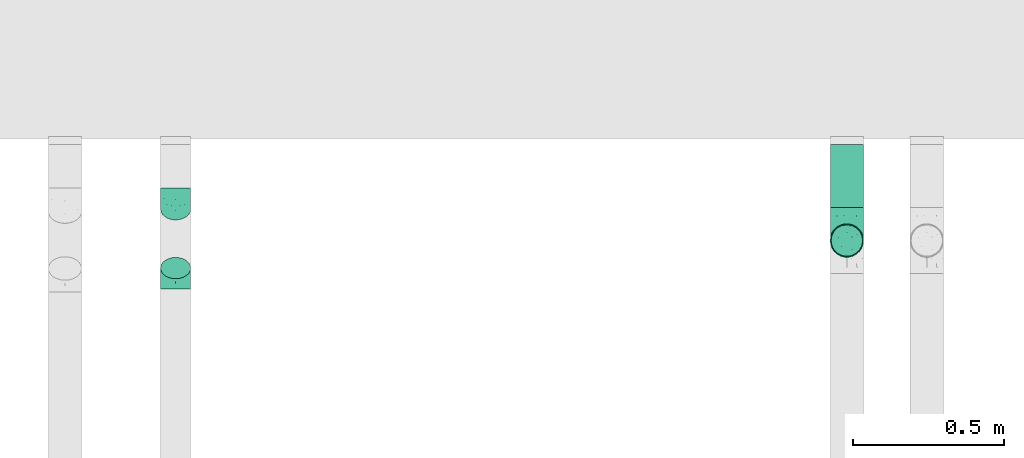
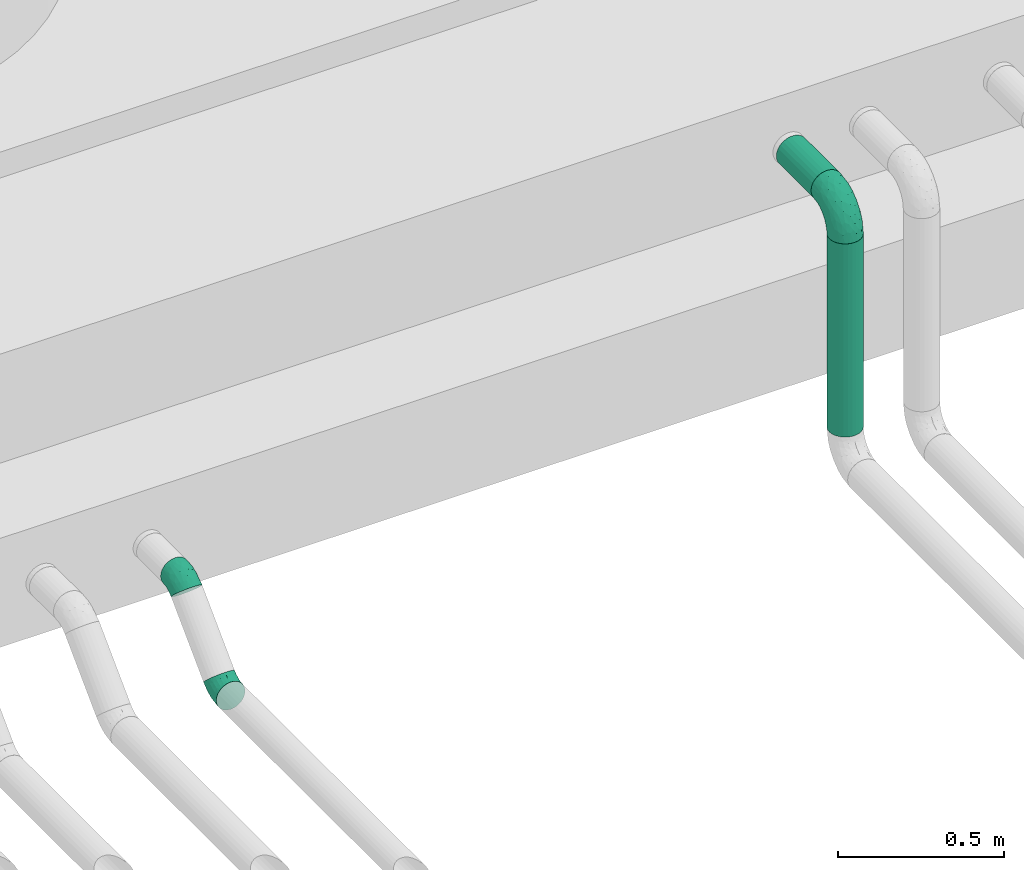
# One storey, part 55 of 91: 3 flow fittings, 2 flow segments.
"""IFC2X3 building model written with IfcOpenShell, lengths in millimetres."""

from ifc_helpers import new_model, entity, si_unit, converted_unit, derived_unit, direction, frame, origin_with_axes, origin_2d_with_axis, place, context, subcontext, project, spatial, hollow_circle, extrude, open_shell, surface_model, source, transform, mapped, material, layer, layer_set, layer_usage, type_object, element, save


model = new_model("IFC2X3")

# Units and contexts
model_context = context("Model", 3, precision=1e-05, world=origin_with_axes(), true_north=direction((0.0, 1.0)))
body_context = subcontext(model_context, "Body", "Model", "MODEL_VIEW")
ifc_project = project(units=[si_unit("AREAUNIT", "SQUARE_METRE"), si_unit("VOLUMEUNIT", "CUBIC_METRE", prefix="DECI"), si_unit("TIMEUNIT", "SECOND"), si_unit("THERMODYNAMICTEMPERATUREUNIT", "DEGREE_CELSIUS"), si_unit("PRESSUREUNIT", "PASCAL"), si_unit("MASSUNIT", "GRAM", prefix="KILO"), si_unit("LENGTHUNIT", "METRE", prefix="MILLI"), si_unit("POWERUNIT", "WATT"), si_unit("ELECTRICCURRENTUNIT", "AMPERE"), si_unit("ELECTRICVOLTAGEUNIT", "VOLT"), derived_unit("VOLUMETRICFLOWRATEUNIT", [(si_unit("VOLUMEUNIT", "CUBIC_METRE", prefix="DECI"), 1), (si_unit("TIMEUNIT", "SECOND"), -1)]), derived_unit("LINEARVELOCITYUNIT", [(si_unit("LENGTHUNIT", "METRE"), 1), (si_unit("TIMEUNIT", "SECOND"), -1)]), derived_unit("MASSDENSITYUNIT", [(si_unit("MASSUNIT", "GRAM", prefix="KILO"), 1), (si_unit("VOLUMEUNIT", "CUBIC_METRE"), -1)]), converted_unit("PLANEANGLEUNIT", "DEGREE", entity("IfcRatioMeasure", 0.01745), si_unit("PLANEANGLEUNIT", "RADIAN"), dimensions=[0, 0, 0, 0, 0, 0, 0])], contexts=[model_context])

# Site, building, storey
site_placement = place(None, origin_with_axes())
site = spatial("IfcSite", under=ifc_project, at=site_placement, CompositionType="ELEMENT")
building_placement = place(site_placement, origin_with_axes())
building = spatial("IfcBuilding", under=site, at=building_placement, Name="mc-building", CompositionType="ELEMENT")
storey_placement = place(building_placement, frame((0.0, 0.0, 8700.0), z_axis=(0.0, 0.0, 1.0), x_axis=(1.0, 0.0, 0.0)))
storey = spatial("IfcBuildingStorey", under=building, at=storey_placement, CompositionType="ELEMENT", Elevation=8700.0)

# Flow segments
ifc_material = material(Name="FZ1")
ifc_layer = layer(ifc_material, 0.0)
ifc_layer_set = layer_set([ifc_layer], Name="FZ1")
ifc_layer_usage = layer_usage(ifc_layer_set, "AXIS1", "POSITIVE", 0.0)
duct_segment_type = type_object("IfcDuctSegmentType", PredefinedType="RIGIDSEGMENT")
shared_shape_1 = source(origin_with_axes(), body_context, "Body", "SweptSolid", [
    extrude(hollow_circle(Radius=55.0, WallThickness=2.0, at=origin_2d_with_axis()), frame((0.0, 0.0, 0.0), z_axis=(1.0, 0.0, 0.0), x_axis=(0.0, 1.0, 0.0)), (0.0, 0.0, 1.0), 709.0),
])
flow_segment_1_placement = place(storey_placement, frame((29788.00747, 2612.35324, 1234.0), z_axis=(0.0, 1.0, 0.0), x_axis=(0.0, 0.0, -1.0)))
element("IfcFlowSegment", 1, at=flow_segment_1_placement, inside=storey, type_object=duct_segment_type, material=ifc_layer_usage, context=body_context, shape_type="MappedRepresentation", body=[
    mapped(shared_shape_1, transform((0.0, 0.0, 0.0), scale=1.0)),
])
shared_shape_2 = source(origin_with_axes(), body_context, "Body", "SweptSolid", [
    extrude(hollow_circle(Radius=55.0, WallThickness=2.0, at=origin_2d_with_axis()), frame((0.0, 0.0, 0.0), z_axis=(1.0, 0.0, 0.0), x_axis=(0.0, 1.0, 0.0)), (0.0, 0.0, 1.0), 208.9),
])
flow_segment_2_placement = place(storey_placement, frame((29788.00747, 2931.20513, 1344.0), z_axis=(0.0, 0.0, 1.0), x_axis=(0.0, -1.0, 0.0)))
element("IfcFlowSegment", 2, at=flow_segment_2_placement, inside=storey, type_object=duct_segment_type, material=ifc_layer_usage, context=body_context, shape_type="MappedRepresentation", body=[
    mapped(shared_shape_2, transform((0.0, 0.0, 0.0), scale=1.0)),
])

# Flow fittings
duct_fitting_type = type_object("IfcDuctFittingType", Name="BU", PredefinedType="BEND")
shared_shape_3 = source(origin_with_axes(), body_context, "Body", "SurfaceModel", [
    surface_model("IfcShellBasedSurfaceModel", [(-110.0, 0.0, -55.0), (-110.0, -14.23505, -53.12592), (-110.0, 14.23505, -53.12592), (-110.0, 53.12592, 14.23505), (-110.0, 27.5, -47.63139), (-110.0, 38.89087, -38.89087), (-110.0, -55.0, 0.0), (-110.0, -53.12592, 14.23505), (-110.0, -38.89087, -38.89087), (-110.0, -27.5, -47.63139), (-110.0, -53.12592, -14.23505), (-110.0, -47.63139, -27.5), (-110.0, -14.23505, 53.12592), (-110.0, 14.23505, 53.12592), (-110.0, 27.5, 47.63139), (-110.0, -47.63139, 27.5), (-110.0, -38.89087, 38.89087), (-110.0, -27.5, 47.63139), (-110.0, 0.0, 55.0), (-110.0, 55.0, 0.0), (-110.0, 53.12592, -14.23505), (-110.0, 47.63139, -27.5), (-110.0, 47.63139, 27.5), (-110.0, 38.89087, 38.89087), (-14.23505, 110.0, -53.12592), (-55.0, 110.0, 0.0), (0.0, 110.0, -55.0), (-27.5, 110.0, -47.63139), (-38.89087, 110.0, -38.89087), (-47.63139, 110.0, -27.5), (38.89087, 110.0, -38.89087), (53.12592, 110.0, 14.23505), (27.5, 110.0, -47.63139), (14.23505, 110.0, -53.12592), (47.63139, 110.0, -27.5), (53.12592, 110.0, -14.23505), (55.0, 110.0, 0.0), (-53.12592, 110.0, -14.23505), (-53.12592, 110.0, 14.23505), (-47.63139, 110.0, 27.5), (-38.89087, 110.0, 38.89087), (-27.5, 110.0, 47.63139), (0.0, 110.0, 55.0), (-14.23505, 110.0, 53.12592), (38.89087, 110.0, 38.89087), (47.63139, 110.0, 27.5), (27.5, 110.0, 47.63139), (14.23505, 110.0, 53.12592), (-64.21732, 48.68956, 43.63444), (-76.6405, 38.18013, 45.55988), (-60.44912, 32.56953, 51.94617), (-76.00813, 5.38378, 55.0), (-90.15553, 11.94394, 54.09138), (-78.5998, 26.77405, 50.81338), (-70.18771, 18.55163, 54.03432), (-75.55424, 54.2118, 32.41257), (-93.27622, 45.77614, 33.48188), (-96.12334, 22.13664, 50.81337), (-21.00813, 45.34362, 55.0), (-18.36258, 70.48427, 54.04484), (-32.04182, 59.64019, 52.24446), (-63.88653, 74.77858, 17.99134), (-74.66383, 63.08407, 19.92123), (-63.60674, 66.07878, 29.97482), (-99.597, 52.72185, 18.52927), (-93.11138, 56.59448, 10.50359), (-98.21577, 57.34403, 0.0), (-53.42855, 92.60092, 21.04759), (-88.54852, 54.8376, 21.04759), (-11.86161, 90.23965, 54.10313), (-5.38378, 76.00813, 55.0), (-57.34403, 98.21577, 0.0), (-56.64619, 93.12774, 10.22088), (-45.34362, 21.00813, 55.0), (-44.60838, 44.60838, 52.13415), (-92.68484, 35.46673, 43.63443), (-22.25266, 95.40765, 50.81337), (-35.97783, 90.61597, 43.63443), (-43.70931, 69.58671, 44.47149), (-27.23711, 77.39884, 50.81337), (-57.2828, 79.3123, 24.9774), (-58.67786, 84.31125, 16.04456), (-82.93277, 60.36161, 12.91784), (-49.88337, 54.51816, 47.224), (-74.57753, 66.83759, 9.55742), (-45.35812, 94.97281, 33.48188), (-59.18663, 88.95241, 0.0), (-51.517, 78.6292, 33.48188), (-65.14788, 80.03077, 0.0), (-56.45322, 62.06476, 39.63545), (-88.95241, 59.18663, 0.0), (-71.10913, 71.10913, 0.0), (-80.03077, 65.14788, 0.0), (-94.9309, 45.36788, -33.48188), (-93.11358, 56.60141, -10.46614), (-99.64997, 52.79499, -18.30015), (-90.20425, 36.08686, -43.63443), (-79.99933, 46.56772, -37.92748), (-76.00813, 5.38378, -55.0), (-72.75364, 19.68651, -53.60527), (-45.34362, 21.00813, -55.0), (-21.91957, 65.12078, -53.85897), (-5.38378, 76.00813, -55.0), (-21.00813, 45.34362, -55.0), (-35.41876, 92.89265, -43.63443), (-91.10309, 11.02766, -54.21832), (-45.77614, 93.27622, -33.48188), (-90.50474, 23.21022, -50.81337), (-70.92854, 33.31794, -49.51754), (-78.52933, 63.35627, -11.73997), (-24.91508, 84.05606, -50.81337), (-88.78941, 54.74452, -21.04759), (-69.59921, 57.34866, -33.48187), (-73.36422, 62.46673, -22.94182), (-63.49062, 67.59111, -28.46929), (-56.59448, 93.11138, -10.50359), (-54.8376, 88.54852, -21.04759), (-54.10679, 75.85581, -32.31867), (-57.75956, 31.09612, -52.80882), (-52.72185, 99.597, -18.52927), (-12.62913, 89.46304, -53.99097), (-34.46825, 66.46123, -50.04329), (-43.9837, 43.9837, -52.42279), (-65.78527, 72.58348, -17.68796), (-70.34468, 43.65295, -44.21951), (-57.47001, 51.99467, -44.91465), (-60.72547, 82.29174, -12.88567), (-42.34915, 74.24548, -43.63444), (-57.25194, 63.5016, -38.08211), (-80.95344, 53.56991, -29.32027), (-52.32891, 4.55257, -54.0482), (32.52942, 47.13398, -30.48571), (14.88266, 20.92917, -33.7947), (14.95561, 36.05775, -42.26543), (30.24048, 70.09027, -41.7461), (19.3559, 65.35825, -48.00507), (-70.35075, -46.44478, -19.5952), (-47.13398, -32.52942, -30.48571), (-28.49299, -30.5778, -16.4009), (-4.55257, 52.32891, -54.0482), (-22.4954, 22.4954, -53.25347), (-75.47368, -11.22546, -52.60718), (-81.32209, -51.5606, -9.98467), (-80.81763, -41.84862, -32.14655), (-70.09027, -30.24048, -41.7461), (-36.05774, -14.95561, -42.26543), (-9.15831, -10.852, -27.8997), (-65.35825, -19.3559, -48.00507), (11.22546, 75.47368, -52.60718), (3.94376, 43.9333, -50.53315), (-13.39742, 13.39743, -48.13058), (-43.9333, -3.94376, -50.53315), (49.37776, 67.29486, 0.0), (41.8609, 47.82256, -9.92641), (50.20582, 74.51695, -9.9731), (18.93131, 11.7156, -17.56239), (-27.5, -32.89419, 0.0), (-1.23348, -12.25375, -12.18106), (41.84862, 80.81763, -32.14655), (35.70604, 41.31408, -20.38235), (46.44478, 70.35075, -19.5952), (32.89419, 27.5, 0.0), (6.67262, -6.67262, 0.0), (-67.29486, -49.37776, 0.0), (-50.36265, -42.95545, -9.51562), (-5.47251, 5.47251, -39.92906), (-70.35075, -46.44478, 19.5952), (-74.51695, -50.20582, 9.9731), (-41.31407, -35.70604, 20.38235), (-47.13398, -32.52942, 30.48571), (-80.81763, -41.84862, 32.14655), (-4.55257, 52.32891, 54.0482), (11.22546, 75.47368, 52.60718), (-43.9333, -3.94376, 50.53315), (-65.35825, -19.3559, 48.00507), (-36.05774, -14.95561, 42.26543), (-70.09027, -30.24048, 41.7461), (-11.7156, -18.93131, 17.56239), (30.5778, 28.49299, 16.4009), (12.25375, 1.23348, 12.18106), (51.5606, 81.32209, 9.98467), (42.95545, 50.36265, 9.51562), (-75.47368, -11.22546, 52.60718), (-52.32891, 4.55257, 54.0482), (3.94376, 43.9333, 50.53315), (-22.4954, 22.4954, 53.25347), (-13.39742, 13.39743, 48.13058), (10.852, 9.15831, 27.8997), (-20.92916, -14.88266, 33.79469), (-47.82256, -41.8609, 9.92641), (32.52942, 47.13398, 30.48571), (46.44478, 70.35075, 19.5952), (41.84862, 80.81763, 32.14655), (30.24048, 70.09027, 41.7461), (19.3559, 65.35825, 48.00507), (14.95561, 36.05775, 42.26543), (-5.47251, 5.47251, 39.92906)], [open_shell([[[0, 1, 2]], [[2, 3, 4]], [[4, 3, 5]], [[2, 6, 7]], [[8, 6, 9]], [[1, 9, 6]], [[10, 6, 11]], [[8, 11, 6]], [[6, 2, 1]], [[12, 13, 14]], [[15, 2, 7]], [[16, 17, 2]], [[2, 17, 12]], [[12, 18, 13]], [[19, 20, 3]], [[5, 3, 21]], [[20, 21, 3]], [[22, 3, 2]], [[23, 22, 2]], [[12, 14, 2]], [[2, 14, 23]], [[15, 16, 2]], [[24, 25, 26]], [[27, 25, 24]], [[25, 28, 29]], [[28, 25, 27]], [[30, 26, 31]], [[26, 30, 32]], [[32, 33, 26]], [[34, 31, 35]], [[31, 34, 30]], [[35, 31, 36]], [[29, 37, 25]], [[38, 39, 26]], [[39, 40, 26]], [[41, 42, 40]], [[42, 26, 40]], [[42, 41, 43]], [[26, 44, 45]], [[31, 26, 45]], [[26, 46, 44]], [[47, 46, 26]], [[42, 47, 26]], [[25, 38, 26]], [[48, 49, 50]], [[18, 51, 52]], [[53, 54, 50]], [[55, 56, 49]], [[56, 22, 23]], [[13, 57, 14]], [[58, 59, 60]], [[61, 62, 63]], [[3, 64, 65]], [[53, 52, 54]], [[3, 65, 66]], [[67, 39, 38]], [[56, 68, 64]], [[65, 64, 68]], [[69, 59, 70]], [[38, 71, 72]], [[73, 58, 74]], [[75, 49, 56]], [[76, 69, 43]], [[53, 57, 52]], [[77, 78, 79]], [[41, 76, 43]], [[43, 69, 42]], [[55, 68, 56]], [[23, 14, 75]], [[76, 77, 79]], [[80, 67, 81]], [[62, 82, 68]], [[60, 78, 83]], [[62, 84, 82]], [[85, 77, 40]], [[81, 67, 72]], [[86, 72, 71]], [[87, 85, 67]], [[61, 81, 88]], [[77, 41, 40]], [[78, 77, 87]], [[23, 75, 56]], [[83, 89, 48]], [[85, 40, 39]], [[62, 68, 55]], [[89, 87, 63]], [[83, 48, 50]], [[57, 75, 14]], [[49, 75, 53]], [[67, 85, 39]], [[87, 77, 85]], [[63, 62, 55]], [[89, 55, 48]], [[80, 63, 87]], [[66, 65, 90]], [[66, 19, 3]], [[84, 91, 92]], [[92, 90, 82]], [[65, 82, 90]], [[61, 84, 62]], [[92, 82, 84]], [[68, 82, 65]], [[3, 22, 64]], [[56, 64, 22]], [[38, 25, 71]], [[81, 72, 86]], [[38, 72, 67]], [[91, 61, 88]], [[80, 81, 61]], [[63, 80, 61]], [[67, 80, 87]], [[77, 76, 41]], [[79, 59, 69]], [[79, 69, 76]], [[42, 69, 70]], [[60, 59, 79]], [[58, 70, 59]], [[78, 60, 79]], [[58, 60, 74]], [[52, 57, 13]], [[75, 57, 53]], [[18, 52, 13]], [[52, 51, 54]], [[51, 73, 54]], [[50, 73, 74]], [[73, 50, 54]], [[50, 74, 83]], [[60, 83, 74]], [[89, 83, 78]], [[87, 89, 78]], [[55, 89, 63]], [[50, 49, 53]], [[55, 49, 48]], [[81, 86, 88]], [[91, 84, 61]], [[5, 21, 93]], [[90, 94, 66]], [[20, 94, 95]], [[96, 93, 97]], [[98, 99, 100]], [[96, 4, 5]], [[101, 102, 103]], [[28, 27, 104]], [[2, 105, 0]], [[104, 106, 28]], [[99, 105, 107]], [[108, 107, 96]], [[90, 109, 94]], [[107, 2, 4]], [[20, 66, 94]], [[27, 24, 110]], [[109, 111, 94]], [[112, 113, 114]], [[37, 115, 71]], [[116, 106, 117]], [[99, 118, 100]], [[116, 115, 119]], [[37, 119, 115]], [[24, 120, 110]], [[121, 110, 101]], [[119, 106, 116]], [[101, 110, 120]], [[122, 103, 100]], [[117, 123, 116]], [[124, 125, 108]], [[115, 116, 126]], [[106, 29, 28]], [[26, 102, 120]], [[127, 104, 110]], [[97, 124, 96]], [[125, 122, 118]], [[128, 127, 125]], [[96, 5, 93]], [[115, 126, 86]], [[117, 106, 127]], [[111, 113, 129]], [[95, 93, 21]], [[97, 129, 112]], [[110, 104, 27]], [[106, 104, 127]], [[96, 107, 4]], [[99, 107, 108]], [[99, 108, 118]], [[105, 99, 98]], [[112, 114, 128]], [[121, 125, 127]], [[20, 19, 66]], [[109, 90, 92]], [[94, 111, 95]], [[91, 123, 109]], [[129, 113, 112]], [[93, 95, 111]], [[21, 20, 95]], [[71, 115, 86]], [[71, 25, 37]], [[123, 91, 88]], [[126, 116, 123]], [[123, 88, 126]], [[86, 126, 88]], [[37, 29, 119]], [[106, 119, 29]], [[129, 93, 111]], [[124, 112, 125]], [[0, 105, 98]], [[107, 105, 2]], [[125, 118, 108]], [[100, 118, 122]], [[93, 129, 97]], [[113, 111, 109]], [[109, 123, 113]], [[114, 123, 117]], [[123, 114, 113]], [[128, 114, 117]], [[127, 128, 117]], [[112, 128, 125]], [[103, 122, 101]], [[110, 121, 127]], [[101, 122, 121]], [[125, 121, 122]], [[26, 120, 24]], [[101, 120, 102]], [[96, 124, 108]], [[92, 91, 109]], [[112, 124, 97]], [[100, 130, 98]], [[131, 132, 133]], [[32, 134, 135]], [[136, 137, 138]], [[139, 140, 103]], [[98, 141, 0]], [[142, 10, 136]], [[143, 144, 137]], [[6, 10, 142]], [[137, 145, 146]], [[144, 147, 145]], [[143, 136, 11]], [[11, 136, 10]], [[8, 143, 11]], [[148, 149, 139]], [[8, 9, 144]], [[9, 1, 147]], [[130, 141, 98]], [[103, 140, 100]], [[148, 135, 149]], [[150, 151, 140]], [[152, 153, 154]], [[130, 140, 151]], [[148, 26, 33]], [[147, 1, 141]], [[155, 146, 132]], [[156, 138, 157]], [[134, 30, 158]], [[150, 140, 149]], [[158, 30, 34]], [[30, 134, 32]], [[153, 159, 160]], [[131, 160, 159]], [[144, 145, 137]], [[36, 152, 154]], [[146, 138, 137]], [[155, 161, 162]], [[158, 160, 131]], [[133, 149, 135]], [[156, 163, 164]], [[163, 142, 164]], [[139, 103, 102]], [[153, 152, 161]], [[34, 35, 160]], [[162, 157, 155]], [[132, 165, 133]], [[157, 146, 155]], [[140, 130, 100]], [[141, 130, 151]], [[141, 151, 147]], [[141, 1, 0]], [[102, 26, 148]], [[140, 139, 149]], [[102, 148, 139]], [[135, 33, 32]], [[151, 150, 145]], [[9, 147, 144]], [[151, 145, 147]], [[145, 165, 146]], [[135, 148, 33]], [[133, 135, 134]], [[131, 133, 134]], [[133, 165, 150]], [[133, 150, 149]], [[145, 150, 165]], [[132, 131, 159]], [[146, 165, 132]], [[160, 158, 34]], [[134, 158, 131]], [[144, 143, 8]], [[136, 143, 137]], [[155, 153, 161]], [[154, 153, 160]], [[153, 155, 159]], [[132, 159, 155]], [[160, 35, 154]], [[36, 154, 35]], [[164, 136, 138]], [[6, 142, 163]], [[136, 164, 142]], [[156, 164, 138]], [[156, 157, 162]], [[146, 157, 138]], [[15, 7, 166]], [[6, 163, 167]], [[168, 169, 166]], [[166, 169, 170]], [[171, 172, 70]], [[173, 174, 175]], [[17, 176, 174]], [[177, 156, 162]], [[176, 16, 170]], [[170, 16, 15]], [[161, 178, 179]], [[152, 180, 181]], [[182, 173, 183]], [[18, 12, 182]], [[184, 185, 186]], [[183, 185, 73]], [[183, 73, 51]], [[177, 187, 188]], [[189, 168, 166]], [[187, 178, 190]], [[16, 176, 17]], [[161, 152, 181]], [[45, 191, 31]], [[45, 44, 192]], [[192, 191, 45]], [[180, 36, 31]], [[193, 194, 195]], [[46, 47, 194]], [[193, 195, 190]], [[193, 44, 46]], [[172, 42, 70]], [[185, 58, 73]], [[189, 163, 156]], [[163, 189, 167]], [[70, 58, 171]], [[184, 171, 185]], [[169, 188, 175]], [[180, 31, 191]], [[192, 193, 190]], [[191, 190, 178]], [[182, 174, 173]], [[194, 47, 172]], [[190, 195, 187]], [[186, 185, 173]], [[162, 179, 177]], [[188, 196, 175]], [[179, 187, 177]], [[185, 171, 58]], [[172, 171, 184]], [[172, 184, 194]], [[172, 47, 42]], [[51, 18, 182]], [[185, 183, 173]], [[51, 182, 183]], [[174, 12, 17]], [[184, 186, 195]], [[46, 194, 193]], [[184, 195, 194]], [[195, 196, 187]], [[174, 182, 12]], [[175, 174, 176]], [[169, 175, 176]], [[175, 196, 186]], [[175, 186, 173]], [[195, 186, 196]], [[188, 169, 168]], [[187, 196, 188]], [[166, 170, 15]], [[176, 170, 169]], [[193, 192, 44]], [[191, 192, 190]], [[177, 189, 156]], [[167, 189, 166]], [[189, 177, 168]], [[188, 168, 177]], [[166, 7, 167]], [[6, 167, 7]], [[181, 191, 178]], [[36, 180, 152]], [[191, 181, 180]], [[161, 181, 178]], [[161, 179, 162]], [[187, 179, 178]]])]),
])
flow_fitting_placement = place(storey_placement, frame((29788.00747, 2612.35324, 1344.0), z_axis=(-1.0, 0.0, 0.0), x_axis=(0.0, 0.0, 1.0)))
element("IfcFlowFitting", 3, at=flow_fitting_placement, inside=storey, type_object=duct_fitting_type, Name="BU", context=body_context, shape_type="MappedRepresentation", body=[
    mapped(shared_shape_3, transform((0.0, 0.0, 0.0), scale=1.0)),
])
shared_shape_4 = source(origin_with_axes(), body_context, "Body", "SurfaceModel", [
    surface_model("IfcShellBasedSurfaceModel", [(-41.0, 0.0, -50.0), (-41.0, -12.94095, -48.29629), (-41.0, 12.94095, -48.29629), (-41.0, 48.29629, 12.94095), (-41.0, 25.0, -43.30127), (-41.0, 43.30127, -25.0), (-41.0, 35.35534, -35.35534), (-41.0, -50.0, 0.0), (-41.0, -48.29629, 12.94095), (-41.0, -35.35534, -35.35534), (-41.0, -25.0, -43.30127), (-41.0, -48.29629, -12.94095), (-41.0, -43.30127, -25.0), (-41.0, 48.29629, -12.94095), (-41.0, 43.30127, 25.0), (-41.0, 35.35534, 35.35534), (-41.0, -12.94095, 48.29629), (-41.0, 25.0, 43.30127), (-41.0, 12.94095, 48.29629), (-41.0, -43.30127, 25.0), (-41.0, -35.35534, 35.35534), (-41.0, -25.0, 43.30127), (-41.0, 0.0, 50.0), (-41.0, 50.0, 0.0), (19.84074, 38.14201, -48.29629), (-6.36396, 64.34672, 0.0), (28.99138, 28.99138, -50.0), (11.31371, 46.66905, -43.30127), (3.99138, 53.99138, -35.35534), (-1.62724, 59.61, -25.0), (53.99138, 3.99138, -35.35534), (63.14201, -5.15926, 12.94095), (46.66905, 11.31371, -43.30127), (38.14201, 19.84074, -48.29629), (59.61, -1.62724, -25.0), (63.14201, -5.15926, -12.94095), (64.34672, -6.36396, 0.0), (-5.15926, 63.14201, -12.94095), (-5.15926, 63.14201, 12.94095), (-1.62724, 59.61, 25.0), (3.99138, 53.99138, 35.35534), (28.99138, 28.99138, 50.0), (11.31371, 46.66905, 43.30127), (19.84074, 38.14201, 48.29629), (59.61, -1.62724, 25.0), (53.99138, 3.99138, 35.35534), (38.14201, 19.84074, 48.29629), (46.66905, 11.31371, 43.30127), (-18.30109, 44.18276, 30.43807), (-24.345, 32.49227, 39.66767), (-6.72766, 39.62131, 39.66767), (-15.38138, 3.37276, 50.0), (-16.23064, 14.00293, 48.89221), (-27.13444, 20.34725, 46.19398), (-6.97826, 50.39468, 30.43807), (-14.60561, 53.26633, 19.13417), (-28.17337, 47.77599, 19.13417), (-16.73188, 55.37236, 9.57436), (-25.91257, 51.41785, 9.5354), (-30.70005, 40.56879, 30.43807), (-10.44327, 25.21228, 46.19398), (1.0295, 20.93716, 48.91923), (-30.42146, 52.10421, 0.0), (4.80032, 33.56273, 46.19826), (-22.25511, 53.72859, 0.0), (-15.33202, 58.35446, 0.0), (8.49138, 13.26118, 50.0), (-5.76099, 40.19002, -39.66767), (4.80032, 33.56273, -46.19826), (-30.70005, 40.56879, -30.43807), (8.49138, 13.26118, -50.0), (-15.38138, 3.37276, -50.0), (1.0295, 20.93716, -48.91923), (-10.44327, 25.21228, -46.19398), (-27.13444, 20.34725, -46.19398), (-23.25933, 32.77367, -39.66767), (-27.33726, 47.99271, -19.13417), (-18.30109, 44.18276, -30.43807), (-6.97826, 50.39468, -30.43807), (-16.23064, 14.00293, -48.89221), (-25.91896, 51.438, -9.42588), (-13.02367, 57.57988, -9.8805), (-13.86114, 53.70431, -19.13417), (2.93034, -7.07447, -47.43371), (2.81434, -16.4825, -43.57717), (12.42788, -30.00357, -29.13965), (40.96913, -21.08746, -18.63201), (15.19143, -36.67536, -14.49606), (-15.58185, -47.0029, -8.91278), (-2.44043, -44.92353, 0.0), (44.2541, -22.21804, -8.91278), (-14.66706, -38.90004, -28.04813), (-6.17907, -26.78474, -38.81666), (37.87766, -17.1353, -28.04813), (-14.05847, -43.88064, -18.63201), (26.52839, -12.54993, -38.91078), (24.22802, -3.41873, -44.68725), (33.49138, -30.04009, 0.0), (-14.05847, -43.88064, 18.63201), (-15.58185, -47.0029, 8.91278), (-14.66706, -38.90004, 28.04813), (15.19143, -36.67536, 14.49606), (2.93034, -7.07447, 47.43371), (9.66485, -13.64492, 43.57717), (12.42788, -30.00357, 29.13965), (40.96913, -21.08746, 18.63201), (37.87766, -17.1353, 28.04813), (-9.88426, -27.63255, 38.91078), (23.30894, -14.57041, 38.81666), (-14.71439, -19.5492, 44.68725), (44.2541, -22.21804, 8.91278)], [open_shell([[[0, 1, 2]], [[2, 3, 4]], [[5, 6, 3]], [[3, 6, 4]], [[2, 7, 8]], [[9, 7, 10]], [[1, 10, 7]], [[11, 7, 12]], [[9, 12, 7]], [[7, 2, 1]], [[13, 5, 3]], [[14, 3, 2]], [[15, 14, 2]], [[16, 17, 2]], [[15, 2, 17]], [[18, 17, 16]], [[8, 19, 2]], [[2, 19, 20]], [[2, 20, 21]], [[16, 2, 21]], [[16, 22, 18]], [[23, 13, 3]], [[24, 25, 26]], [[27, 25, 24]], [[25, 28, 29]], [[27, 28, 25]], [[30, 26, 31]], [[26, 30, 32]], [[32, 33, 26]], [[34, 31, 35]], [[34, 30, 31]], [[36, 35, 31]], [[37, 25, 29]], [[26, 38, 39]], [[26, 39, 40]], [[41, 40, 42]], [[40, 41, 26]], [[41, 42, 43]], [[44, 31, 26]], [[45, 44, 26]], [[46, 47, 26]], [[45, 26, 47]], [[26, 41, 46]], [[25, 38, 26]], [[48, 49, 50]], [[22, 51, 52]], [[17, 49, 15]], [[53, 17, 18]], [[49, 17, 53]], [[54, 50, 40]], [[48, 55, 56]], [[55, 57, 58]], [[59, 14, 15]], [[60, 53, 52]], [[50, 49, 60]], [[58, 3, 56]], [[52, 51, 61]], [[62, 23, 3]], [[63, 50, 60]], [[50, 42, 40]], [[3, 58, 62]], [[43, 61, 41]], [[62, 58, 64]], [[48, 59, 49]], [[14, 56, 3]], [[40, 39, 54]], [[57, 64, 58]], [[39, 38, 55]], [[63, 60, 61]], [[54, 55, 48]], [[65, 57, 38]], [[56, 14, 59]], [[38, 25, 65]], [[60, 52, 61]], [[49, 59, 15]], [[55, 58, 56]], [[56, 59, 48]], [[55, 54, 39]], [[50, 54, 48]], [[18, 22, 52]], [[49, 53, 60]], [[18, 52, 53]], [[61, 51, 66]], [[41, 61, 66]], [[63, 61, 43]], [[43, 42, 63]], [[50, 63, 42]], [[38, 57, 55]], [[64, 57, 65]], [[67, 27, 68]], [[69, 6, 5]], [[70, 71, 72]], [[73, 74, 75]], [[76, 77, 69]], [[28, 78, 29]], [[2, 79, 0]], [[13, 23, 62]], [[2, 74, 79]], [[6, 75, 4]], [[77, 78, 67]], [[13, 62, 80]], [[64, 80, 62]], [[81, 80, 64]], [[67, 73, 75]], [[82, 77, 76]], [[81, 64, 65]], [[76, 69, 5]], [[82, 76, 80]], [[24, 72, 68]], [[74, 2, 4]], [[27, 67, 28]], [[26, 70, 72]], [[69, 75, 6]], [[82, 29, 78]], [[72, 71, 79]], [[5, 13, 76]], [[77, 67, 75]], [[13, 80, 76]], [[82, 37, 29]], [[81, 25, 37]], [[82, 81, 37]], [[75, 69, 77]], [[67, 78, 28]], [[82, 78, 77]], [[75, 74, 4]], [[79, 74, 73]], [[79, 73, 72]], [[79, 71, 0]], [[68, 72, 73]], [[26, 72, 24]], [[67, 68, 73]], [[27, 24, 68]], [[80, 81, 82]], [[25, 81, 65]], [[1, 83, 84]], [[85, 86, 87]], [[0, 71, 1]], [[88, 87, 89]], [[90, 86, 35]], [[91, 92, 85]], [[11, 88, 7]], [[30, 34, 93]], [[11, 12, 94]], [[92, 91, 9]], [[85, 94, 91]], [[94, 85, 87]], [[95, 93, 85]], [[85, 92, 95]], [[83, 71, 70]], [[12, 9, 91]], [[70, 26, 33]], [[96, 84, 83]], [[1, 71, 83]], [[95, 96, 32]], [[95, 30, 93]], [[95, 32, 30]], [[97, 89, 87]], [[34, 86, 93]], [[36, 97, 90]], [[94, 88, 11]], [[34, 35, 86]], [[90, 87, 86]], [[93, 86, 85]], [[32, 96, 33]], [[84, 10, 1]], [[33, 83, 70]], [[94, 12, 91]], [[10, 92, 9]], [[87, 88, 94]], [[7, 88, 89]], [[36, 90, 35]], [[87, 90, 97]], [[84, 95, 92]], [[33, 96, 83]], [[95, 84, 96]], [[10, 84, 92]], [[8, 98, 19]], [[7, 89, 99]], [[19, 98, 100]], [[101, 98, 99]], [[46, 102, 103]], [[104, 105, 106]], [[100, 98, 104]], [[107, 104, 108]], [[16, 51, 22]], [[51, 16, 102]], [[107, 20, 100]], [[107, 109, 21]], [[21, 20, 107]], [[103, 47, 46]], [[101, 89, 97]], [[105, 110, 31]], [[45, 47, 108]], [[105, 104, 101]], [[107, 100, 104]], [[31, 110, 36]], [[109, 16, 21]], [[108, 106, 45]], [[105, 44, 106]], [[41, 66, 46]], [[102, 66, 51]], [[46, 66, 102]], [[104, 98, 101]], [[99, 98, 8]], [[106, 108, 104]], [[110, 101, 97]], [[44, 45, 106]], [[105, 31, 44]], [[20, 19, 100]], [[109, 103, 102]], [[101, 110, 105]], [[36, 110, 97]], [[7, 99, 8]], [[101, 99, 89]], [[103, 107, 108]], [[16, 109, 102]], [[107, 103, 109]], [[47, 103, 108]]])]),
])
for number, where, z_axis, x_axis, name in (
    (4, (27561.56962, 2745.06047, 668.0), (-1.0, 0.0, 0.0), (0.0, 0.707107, 0.707107), "BU"),
    (5, (27561.56962, 2492.06047, 415.0), (1.0, 0.0, 0.0), (0.0, 1.0, 0.0), "BU"),
):
    element("IfcFlowFitting", number, at=place(storey_placement, frame(where, z_axis=z_axis, x_axis=x_axis)), inside=storey, type_object=duct_fitting_type, Name=name, context=body_context, shape_type="MappedRepresentation", body=[
        mapped(shared_shape_4, transform((0.0, 0.0, 0.0), scale=1.0)),
    ])

save(model, "model.ifc")
